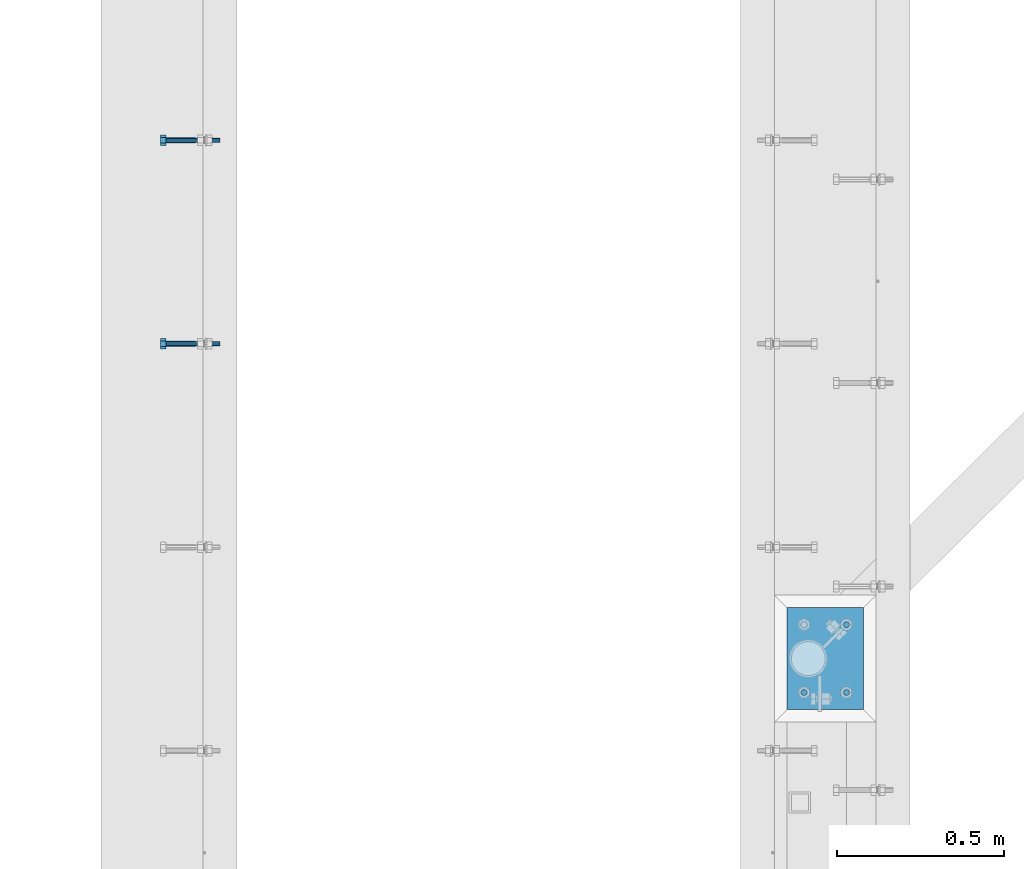
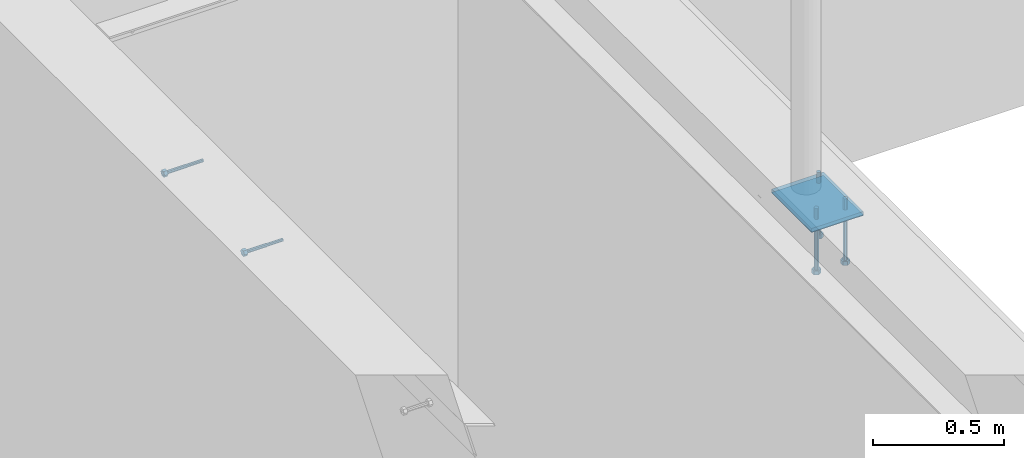
# One storey, part 419 of 975: 7 beams.
"""IFC2X3 building model written with IfcOpenShell, lengths in millimetres."""

from ifc_helpers import new_model, si_unit, frame, origin_with_axes, place, context, subcontext, project, spatial, faceted_brep, material, type_object, element, save


model = new_model("IFC2X3")

# Units and contexts
model_context = context("Model", 3, precision=1e-05, world=origin_with_axes())
body_context = subcontext(model_context, "Body", "Model", "MODEL_VIEW")
ifc_project = project(units=[si_unit("LENGTHUNIT", "METRE", prefix="MILLI"), si_unit("AREAUNIT", "SQUARE_METRE"), si_unit("VOLUMEUNIT", "CUBIC_METRE"), si_unit("MASSUNIT", "GRAM", prefix="KILO"), si_unit("TIMEUNIT", "SECOND"), si_unit("PLANEANGLEUNIT", "RADIAN"), si_unit("SOLIDANGLEUNIT", "STERADIAN"), si_unit("THERMODYNAMICTEMPERATUREUNIT", "DEGREE_CELSIUS"), si_unit("LUMINOUSINTENSITYUNIT", "LUMEN")], contexts=[model_context])

# Site, building, storey
site_placement = place(None, origin_with_axes())
site = spatial("IfcSite", under=ifc_project, at=site_placement, CompositionType="ELEMENT")
building_placement = place(site_placement, origin_with_axes())
building = spatial("IfcBuilding", under=site, at=building_placement, Name="Undefined", CompositionType="ELEMENT")
storey_placement = place(building_placement, origin_with_axes())
storey = spatial("IfcBuildingStorey", under=building, at=storey_placement, Name="Undefined", CompositionType="ELEMENT", Elevation=0.0)

# Beams
ifc_material_1 = material(Name="STEEL/F1554-36")
beam_type_1 = type_object("IfcBeamType", PredefinedType="NOTDEFINED")
beam_1_placement = place(storey_placement, frame((282.574953372507, 16951.3248045215, 3835.4), z_axis=(0.0, 0.0, -1.0), x_axis=(-0.999999999999998, 6.90000001668524e-08, 0.0)))
element("IfcBeam", 1, at=beam_1_placement, inside=storey, type_object=beam_type_1, material=ifc_material_1, Name="HEADED_ANCHOR_BOLT", context=body_context, shape_type="Brep", body=[
    faceted_brep([(88.9000000184824, 7.94000001861696, -13.7499999799138), (88.8999999527368, 15.8800000758411, 2.00943759409711e-08), (104.774999952569, 15.8800001213949, 6.97191353538074e-08), (104.775000018315, 7.94000006417082, -13.7499999302891), (88.900000064019, -7.94000009583215, -13.7499999799147), (104.775000063852, -7.9400000502792, -13.74999993029), (88.9000000438027, -15.880000153059, 2.00925569515675e-08), (104.775000043643, -15.8800001075042, 6.9716406869702e-08), (88.8999999780608, -7.94000009583488, 13.7500000200998), (104.774999977893, -7.94000005028101, 13.7500000697237), (88.8999999325279, 7.94000001861514, 13.7500000201007), (104.774999932361, 7.940000064169, 13.7500000697246), (88.9000000119959, 3.78780480527439, -7.86545778426807), (88.8999999957159, 6.82538844544797, -5.4430656647246), (88.8999999799416, 8.51112018845743, -1.94260763148395), (88.8999999677944, 8.51112018845652, 1.94260767167179), (88.8999999616899, 6.82538844544615, 5.44306570491244), (88.8999999628249, 3.78780480527257, 7.86545782445592), (88.8999999709849, -3.86089595849626e-08, 8.72999956233434), (88.8999999845473, -3.7878048824914, 7.8654578244541), (88.9000000008309, -6.82538852266407, 5.44306570491153), (88.9000000166052, -8.51112026567444, 1.94260767166998), (88.9000000287488, -8.51112026567353, -1.94260763148577), (88.9000000348606, -6.82538852266407, -5.44306566472642), (88.9000000337182, -3.78780488248958, -7.86545778426898), (88.9000000255583, -3.86080500902608e-08, -8.72999952214832), (104.775000025395, 6.94581103743985e-09, -8.72999947252447), (104.775000011829, 3.78780485082825, -7.86545773464422), (104.774999995549, 6.82538849100092, -5.44306561510075), (104.774999979774, 8.51112023401038, -1.9426075818601), (104.774999967627, 8.51112023401038, 1.94260772129564), (104.774999961523, 6.82538849100092, 5.44306575453629), (104.774999962658, 3.78780485082643, 7.86545787407977), (104.774999970818, 6.94399204803631e-09, 8.7299996119591), (104.77499998438, -3.78780483693754, 7.86545787407886), (104.775000000664, -6.82538847711112, 5.44306575453538), (104.775000016438, -8.51112022012057, 1.94260772129473), (104.775000028581, -8.51112022012057, -1.94260758186101), (104.775000034693, -6.82538847711021, -5.44306561510166), (104.775000033551, -3.78780483693663, -7.86545773464422), (-2.99107341561466e-07, -5.61266007567065, 5.61266007566792), (-4.22995071858168e-07, -7.93750000000728, 0.0), (104.774999998088, -7.93749999999, -4.45652403868735e-11), (104.774999998088, -5.61266007565791, 5.61266007562426), (-1.09139364212751e-11, 1.81898940354586e-12, 7.9375), (104.774999998095, 1.18234311230481e-11, 7.93749999995816), (2.99089151667431e-07, 5.61266007567428, 5.61266007566792), (104.774999998102, 5.61266007568065, 5.61266007562517), (4.22980519942939e-07, 7.93750000001091, 0.0), (104.77499999811, 7.93750000001364, -4.36557456851006e-11), (2.99089151667431e-07, 5.61266007567428, -5.61266007566792), (104.774999998102, 5.61266007568156, -5.61266007571339), (-1.09139364212751e-11, 1.81898940354586e-12, -7.9375), (104.774999998099, 1.2732925824821e-11, -7.93750000004547), (-73.0249999592124, 5.05157065939329, -5.0515715445581), (-73.0249999269472, -1.85405951924622e-07, -7.14400069976364), (-73.0249999328516, -5.0515710302052, -5.05157154455992), (-73.0249999734697, -7.14400018541073, -6.9975976657588e-07), (-73.0250000250016, -5.05157103020611, 5.05157014504039), (-73.0250000572705, -1.85406861419324e-07, 7.1439993002441), (-73.0250000513661, 5.05157065939238, 5.05157014503948), (-73.025000010748, 7.14399981459792, -6.99758857081179e-07), (0.00625003290042514, 5.05157085007795, -5.05157087849238), (0.00625006516929716, 5.27870724909008e-09, -7.1440000336961), (0.00625005926485755, -5.05157083952145, -5.05157087849329), (0.00625001864682417, -7.14399999472516, -3.36940502165817e-08), (0.00624996711121639, -5.05157083952145, 5.05157081110519), (0.00624993484598235, 5.2777977543883e-09, 7.14399996631164), (0.00624994074678398, 5.05157085007704, 5.05157081110701), (0.00624998136845534, 7.14400000528167, -3.36922312271781e-08), (-2.99107341561466e-07, -5.61266007567065, -5.61266007566792), (104.774999998092, -5.612660075657, -5.6126600757143)], [[[0, 1, 2, 3]], [[4, 0, 3, 5]], [[6, 4, 5, 7]], [[8, 6, 7, 9]], [[10, 8, 9, 11]], [[0, 4, 6, 8, 10, 1], [12, 13, 14, 15, 16, 17, 18, 19, 20, 21, 22, 23, 24, 25]], [[12, 25, 26, 27]], [[13, 12, 27, 28]], [[14, 13, 28, 29]], [[15, 14, 29, 30]], [[16, 15, 30, 31]], [[17, 16, 31, 32]], [[18, 17, 32, 33]], [[19, 18, 33, 34]], [[20, 19, 34, 35]], [[21, 20, 35, 36]], [[22, 21, 36, 37]], [[23, 22, 37, 38]], [[24, 23, 38, 39]], [[25, 24, 39, 26]], [[9, 7, 5, 3, 2, 11], [38, 37, 36, 35, 34, 33, 32, 31, 30, 29, 28, 27, 26, 39]], [[1, 10, 11, 2]], [[40, 41, 42, 43]], [[44, 40, 43, 45]], [[46, 44, 45, 47]], [[48, 46, 47, 49]], [[50, 48, 49, 51]], [[52, 50, 51, 53]], [[54, 55, 56, 57, 58, 59, 60, 61]], [[55, 54, 62, 63]], [[56, 55, 63, 64]], [[57, 56, 64, 65]], [[58, 57, 65, 66]], [[59, 58, 66, 67]], [[60, 59, 67, 68]], [[61, 60, 68, 69]], [[54, 61, 69, 62]], [[40, 44, 46, 48, 50, 52, 70, 41], [68, 67, 66, 65, 64, 63, 62, 69]], [[41, 70, 71, 42]], [[53, 51, 49, 47, 45, 43, 42, 71]], [[70, 52, 53, 71]]]),
])
beam_2_placement = place(storey_placement, frame((282.574957639707, 16341.7251951465, 3835.4), z_axis=(0.0, 0.0, -1.0), x_axis=(-0.999999999999998, 6.90000001668524e-08, 0.0)))
element("IfcBeam", 2, at=beam_2_placement, inside=storey, type_object=beam_type_1, material=ifc_material_1, Name="HEADED_ANCHOR_BOLT", context=body_context, shape_type="Brep", body=[
    faceted_brep([(88.9000000184824, 7.94000001861696, -13.7499999799138), (88.8999999527368, 15.8800000758411, 2.00943759409711e-08), (104.774999952569, 15.8800001213949, 6.97191353538074e-08), (104.775000018315, 7.94000006417082, -13.7499999302891), (88.900000064019, -7.94000009583215, -13.7499999799147), (104.775000063852, -7.9400000502792, -13.74999993029), (88.9000000438027, -15.880000153059, 2.00925569515675e-08), (104.775000043643, -15.8800001075042, 6.9716406869702e-08), (88.8999999780608, -7.94000009583488, 13.7500000200998), (104.774999977893, -7.94000005028101, 13.7500000697237), (88.8999999325279, 7.94000001861514, 13.7500000201007), (104.774999932361, 7.940000064169, 13.7500000697246), (88.9000000119959, 3.78780480527439, -7.86545778426807), (88.8999999957159, 6.82538844544797, -5.4430656647246), (88.8999999799416, 8.51112018845743, -1.94260763148395), (88.8999999677944, 8.51112018845652, 1.94260767167179), (88.8999999616899, 6.82538844544615, 5.44306570491244), (88.8999999628249, 3.78780480527257, 7.86545782445592), (88.8999999709849, -3.86089595849626e-08, 8.72999956233434), (88.8999999845473, -3.7878048824914, 7.8654578244541), (88.9000000008309, -6.82538852266407, 5.44306570491153), (88.9000000166052, -8.51112026567444, 1.94260767166998), (88.9000000287488, -8.51112026567353, -1.94260763148577), (88.9000000348606, -6.82538852266407, -5.44306566472642), (88.9000000337182, -3.78780488248958, -7.86545778426898), (88.9000000255583, -3.86080500902608e-08, -8.72999952214832), (104.775000025395, 6.94581103743985e-09, -8.72999947252447), (104.775000011829, 3.78780485082825, -7.86545773464422), (104.774999995549, 6.82538849100092, -5.44306561510075), (104.774999979774, 8.51112023401038, -1.9426075818601), (104.774999967627, 8.51112023401038, 1.94260772129564), (104.774999961523, 6.82538849100092, 5.44306575453629), (104.774999962658, 3.78780485082643, 7.86545787407977), (104.774999970818, 6.94399204803631e-09, 8.7299996119591), (104.77499998438, -3.78780483693754, 7.86545787407886), (104.775000000664, -6.82538847711112, 5.44306575453538), (104.775000016438, -8.51112022012057, 1.94260772129473), (104.775000028581, -8.51112022012057, -1.94260758186101), (104.775000034693, -6.82538847711021, -5.44306561510166), (104.775000033551, -3.78780483693663, -7.86545773464422), (-2.99107341561466e-07, -5.61266007567065, 5.61266007566792), (-4.22995071858168e-07, -7.93750000000728, 0.0), (104.774999998088, -7.93749999999, -4.45652403868735e-11), (104.774999998088, -5.61266007565791, 5.61266007562426), (-1.09139364212751e-11, 1.81898940354586e-12, 7.9375), (104.774999998095, 1.18234311230481e-11, 7.93749999995816), (2.99089151667431e-07, 5.61266007567428, 5.61266007566792), (104.774999998102, 5.61266007568065, 5.61266007562517), (4.22980519942939e-07, 7.93750000001091, 0.0), (104.77499999811, 7.93750000001364, -4.36557456851006e-11), (2.99089151667431e-07, 5.61266007567428, -5.61266007566792), (104.774999998102, 5.61266007568156, -5.61266007571339), (-1.09139364212751e-11, 1.81898940354586e-12, -7.9375), (104.774999998099, 1.2732925824821e-11, -7.93750000004547), (-73.0249999592124, 5.05157065939329, -5.0515715445581), (-73.0249999269472, -1.85405951924622e-07, -7.14400069976364), (-73.0249999328516, -5.0515710302052, -5.05157154455992), (-73.0249999734697, -7.14400018541073, -6.9975976657588e-07), (-73.0250000250016, -5.05157103020611, 5.05157014504039), (-73.0250000572705, -1.85406861419324e-07, 7.1439993002441), (-73.0250000513661, 5.05157065939238, 5.05157014503948), (-73.025000010748, 7.14399981459792, -6.99758857081179e-07), (0.00625003290042514, 5.05157085007795, -5.05157087849238), (0.00625006516929716, 5.27870724909008e-09, -7.1440000336961), (0.00625005926485755, -5.05157083952145, -5.05157087849329), (0.00625001864682417, -7.14399999472516, -3.36940502165817e-08), (0.00624996711121639, -5.05157083952145, 5.05157081110519), (0.00624993484598235, 5.2777977543883e-09, 7.14399996631164), (0.00624994074678398, 5.05157085007704, 5.05157081110701), (0.00624998136845534, 7.14400000528167, -3.36922312271781e-08), (-2.99107341561466e-07, -5.61266007567065, -5.61266007566792), (104.774999998092, -5.612660075657, -5.6126600757143)], [[[0, 1, 2, 3]], [[4, 0, 3, 5]], [[6, 4, 5, 7]], [[8, 6, 7, 9]], [[10, 8, 9, 11]], [[0, 4, 6, 8, 10, 1], [12, 13, 14, 15, 16, 17, 18, 19, 20, 21, 22, 23, 24, 25]], [[12, 25, 26, 27]], [[13, 12, 27, 28]], [[14, 13, 28, 29]], [[15, 14, 29, 30]], [[16, 15, 30, 31]], [[17, 16, 31, 32]], [[18, 17, 32, 33]], [[19, 18, 33, 34]], [[20, 19, 34, 35]], [[21, 20, 35, 36]], [[22, 21, 36, 37]], [[23, 22, 37, 38]], [[24, 23, 38, 39]], [[25, 24, 39, 26]], [[9, 7, 5, 3, 2, 11], [38, 37, 36, 35, 34, 33, 32, 31, 30, 29, 28, 27, 26, 39]], [[1, 10, 11, 2]], [[40, 41, 42, 43]], [[44, 40, 43, 45]], [[46, 44, 45, 47]], [[48, 46, 47, 49]], [[50, 48, 49, 51]], [[52, 50, 51, 53]], [[54, 55, 56, 57, 58, 59, 60, 61]], [[55, 54, 62, 63]], [[56, 55, 63, 64]], [[57, 56, 64, 65]], [[58, 57, 65, 66]], [[59, 58, 66, 67]], [[60, 59, 67, 68]], [[61, 60, 68, 69]], [[54, 61, 69, 62]], [[40, 44, 46, 48, 50, 52, 70, 41], [68, 67, 66, 65, 64, 63, 62, 69]], [[41, 70, 71, 42]], [[53, 51, 49, 47, 45, 43, 42, 71]], [[70, 52, 53, 71]]]),
])
beam_type_2 = type_object("IfcBeamType", PredefinedType="NOTDEFINED")
beam_3_placement = place(storey_placement, frame((2232.02500137409, 15500.3500011752, 3917.95), z_axis=(1.0, 0.0, 0.0), x_axis=(0.0, 0.0, -1.0)))
element("IfcBeam", 3, at=beam_3_placement, inside=storey, type_object=beam_type_2, material=ifc_material_1, Name="HEADED_BOLT", context=body_context, shape_type="Brep", body=[
    faceted_brep([(196.84375, -9.12999965559902, 15.8099993757314), (196.84375, -18.2599997700399, -1.0438852768857e-06), (215.893749999999, -18.2599997700399, -1.0438852768857e-06), (215.893749999999, -9.12999965559902, 15.8099993757314), (196.84375, 9.13000057328281, 15.8099993757314), (215.893749999999, 9.13000057328281, 15.8099993757314), (196.84375, 18.2600006877237, -1.0438852768857e-06), (215.893749999999, 18.2600006877237, -1.0438852768857e-06), (196.84375, 9.13000057328281, -15.810001463502), (215.893749999999, 9.13000057328281, -15.810001463502), (196.84375, -9.12999965559902, -15.810001463502), (215.893749999999, -9.12999965559902, -15.810001463502), (196.84375, -4.47767959644079, 9.2979973979138), (196.84375, -8.06850020163256, 6.43441352102286), (196.84375, -10.0612552973498, 2.29641492663589), (196.84375, -10.0612552973498, -2.29641701440644), (196.84375, -8.06850020163256, -6.43441560879344), (196.84375, -4.47767959644079, -9.29799948568439), (196.84375, 4.58841896033846e-07, -10.3200007387095), (196.84375, 4.47768051412459, -9.29799948568436), (196.84375, 8.06850111931635, -6.43441560879342), (196.84375, 10.0612562150336, -2.29641701440644), (196.84375, 10.0612562150336, 2.29641492663589), (196.84375, 8.06850111931635, 6.43441352102289), (196.84375, 4.47768051412459, 9.29799739791383), (196.84375, 4.58841896033846e-07, 10.3199986509389), (215.893749999999, 4.58841896033846e-07, 10.3199986509389), (215.893749999999, -4.47767959644079, 9.2979973979138), (215.893749999999, -8.06850020163256, 6.43441352102286), (215.893749999999, -10.0612552973498, 2.29641492663589), (215.893749999999, -10.0612552973498, -2.29641701440644), (215.893749999999, -8.06850020163256, -6.43441560879344), (215.893749999999, -4.47767959644079, -9.29799948568439), (215.893749999999, 4.58841896033846e-07, -10.3200007387095), (215.893749999999, 4.47768051412459, -9.29799948568436), (215.893749999999, 8.06850111931635, -6.43441560879342), (215.893749999999, 10.0612562150336, -2.29641701440644), (215.893749999999, 10.0612562150336, 2.29641492663589), (215.893749999999, 8.06850111931635, 6.43441352102289), (215.893749999999, 4.47768051412459, 9.29799739791383), (0.0, -6.73519209080223, 6.73519209080186), (0.0, -9.52499999999964, 0.0), (215.900000000001, -9.52499999999964, 0.0), (215.900000000001, -6.73519209080223, 6.73519209080186), (-9.87109982941227e-13, -1.20792265079217e-13, 9.52499961853027), (215.900000000001, 0.0, 9.52500000000001), (0.0, 6.73519209080223, 6.73519209080186), (215.900000000001, 6.73519209080223, 6.73519209080186), (0.0, 9.52499999999964, 0.0), (215.900000000001, 9.52499999999964, 0.0), (0.0, 6.73519209080223, -6.73519209080186), (215.900000000001, 6.73519209080223, -6.73519209080186), (2.95075507493764e-12, -1.20792265079217e-13, -9.52499961853027), (215.900000000001, 0.0, -9.52500000000001), (-88.9444446471748, -6.3639605718372, 6.39952908988423), (-88.9433906823501, 4.58841896033846e-07, 9.03556784850662), (-88.9444446471748, 6.36396148952099, 6.39952908988423), (-88.9469891433491, 9.0000004588419, 0.0355685678769078), (-88.9495336395235, 6.36396148952099, -6.32839195413041), (-88.9505876043481, 4.58841896033846e-07, -8.9644307127528), (-88.9495336395235, -6.3639605718372, -6.32839195413041), (-88.9469891433491, -8.9999995411581, 0.0355685678769078), (0.0124298302243915, 6.36396148952099, -6.36396152997716), (0.0113758653997138, 4.58841896033846e-07, -9.00000028859955), (0.0124298302243915, -6.3639605718372, -6.36396152997716), (0.0149743263987148, -8.9999995411581, -1.00796984270346e-06), (0.0175188225730381, -6.3639605718372, 6.36395951403748), (0.0185727873977157, 4.58841896033846e-07, 8.99999827265987), (0.0175188225730381, 6.36396148952099, 6.36395951403748), (0.0149743263987148, 9.0000004588419, -1.00796984270346e-06), (0.0, -6.73519209080223, -6.73519209080186), (215.900000000001, -6.73519209080223, -6.73519209080186)], [[[0, 1, 2, 3]], [[4, 0, 3, 5]], [[6, 4, 5, 7]], [[8, 6, 7, 9]], [[10, 8, 9, 11]], [[0, 4, 6, 8, 10, 1], [12, 13, 14, 15, 16, 17, 18, 19, 20, 21, 22, 23, 24, 25]], [[12, 25, 26, 27]], [[13, 12, 27, 28]], [[14, 13, 28, 29]], [[15, 14, 29, 30]], [[16, 15, 30, 31]], [[17, 16, 31, 32]], [[18, 17, 32, 33]], [[19, 18, 33, 34]], [[20, 19, 34, 35]], [[21, 20, 35, 36]], [[22, 21, 36, 37]], [[23, 22, 37, 38]], [[24, 23, 38, 39]], [[25, 24, 39, 26]], [[9, 7, 5, 3, 2, 11], [38, 37, 36, 35, 34, 33, 32, 31, 30, 29, 28, 27, 26, 39]], [[1, 10, 11, 2]], [[40, 41, 42, 43]], [[44, 40, 43, 45]], [[46, 44, 45, 47]], [[48, 46, 47, 49]], [[50, 48, 49, 51]], [[52, 50, 51, 53]], [[54, 55, 56, 57, 58, 59, 60, 61]], [[59, 58, 62, 63]], [[60, 59, 63, 64]], [[61, 60, 64, 65]], [[54, 61, 65, 66]], [[55, 54, 66, 67]], [[56, 55, 67, 68]], [[57, 56, 68, 69]], [[58, 57, 69, 62]], [[40, 44, 46, 48, 50, 52, 70, 41], [68, 67, 66, 65, 64, 63, 62, 69]], [[41, 70, 71, 42]], [[53, 51, 49, 47, 45, 43, 42, 71]], [[70, 52, 53, 71]]]),
])
beam_4_placement = place(storey_placement, frame((2232.02500137409, 15297.1500011752, 3917.95), z_axis=(1.0, 0.0, 0.0), x_axis=(0.0, 0.0, -1.0)))
element("IfcBeam", 4, at=beam_4_placement, inside=storey, type_object=beam_type_2, material=ifc_material_1, Name="HEADED_BOLT", context=body_context, shape_type="Brep", body=[
    faceted_brep([(196.84375, -9.12999965559902, 15.8099993757314), (196.84375, -18.2599997700399, -1.0438852768857e-06), (215.893749999999, -18.2599997700399, -1.0438852768857e-06), (215.893749999999, -9.12999965559902, 15.8099993757314), (196.84375, 9.13000057328281, 15.8099993757314), (215.893749999999, 9.13000057328281, 15.8099993757314), (196.84375, 18.2600006877237, -1.0438852768857e-06), (215.893749999999, 18.2600006877237, -1.0438852768857e-06), (196.84375, 9.13000057328281, -15.810001463502), (215.893749999999, 9.13000057328281, -15.810001463502), (196.84375, -9.12999965559902, -15.810001463502), (215.893749999999, -9.12999965559902, -15.810001463502), (196.84375, -4.47767959644079, 9.2979973979138), (196.84375, -8.06850020163256, 6.43441352102286), (196.84375, -10.0612552973498, 2.29641492663589), (196.84375, -10.0612552973498, -2.29641701440644), (196.84375, -8.06850020163256, -6.43441560879344), (196.84375, -4.47767959644079, -9.29799948568439), (196.84375, 4.58841896033846e-07, -10.3200007387095), (196.84375, 4.47768051412459, -9.29799948568436), (196.84375, 8.06850111931635, -6.43441560879342), (196.84375, 10.0612562150336, -2.29641701440644), (196.84375, 10.0612562150336, 2.29641492663589), (196.84375, 8.06850111931635, 6.43441352102289), (196.84375, 4.47768051412459, 9.29799739791383), (196.84375, 4.58841896033846e-07, 10.3199986509389), (215.893749999999, 4.58841896033846e-07, 10.3199986509389), (215.893749999999, -4.47767959644079, 9.2979973979138), (215.893749999999, -8.06850020163256, 6.43441352102286), (215.893749999999, -10.0612552973498, 2.29641492663589), (215.893749999999, -10.0612552973498, -2.29641701440644), (215.893749999999, -8.06850020163256, -6.43441560879344), (215.893749999999, -4.47767959644079, -9.29799948568439), (215.893749999999, 4.58841896033846e-07, -10.3200007387095), (215.893749999999, 4.47768051412459, -9.29799948568436), (215.893749999999, 8.06850111931635, -6.43441560879342), (215.893749999999, 10.0612562150336, -2.29641701440644), (215.893749999999, 10.0612562150336, 2.29641492663589), (215.893749999999, 8.06850111931635, 6.43441352102289), (215.893749999999, 4.47768051412459, 9.29799739791383), (0.0, -6.73519209080223, 6.73519209080186), (0.0, -9.52499999999964, 0.0), (215.900000000001, -9.52499999999964, 0.0), (215.900000000001, -6.73519209080223, 6.73519209080186), (-9.87109982941227e-13, -1.20792265079217e-13, 9.52499961853027), (215.900000000001, 0.0, 9.52500000000001), (0.0, 6.73519209080223, 6.73519209080186), (215.900000000001, 6.73519209080223, 6.73519209080186), (0.0, 9.52499999999964, 0.0), (215.900000000001, 9.52499999999964, 0.0), (0.0, 6.73519209080223, -6.73519209080186), (215.900000000001, 6.73519209080223, -6.73519209080186), (2.95075507493764e-12, -1.20792265079217e-13, -9.52499961853027), (215.900000000001, 0.0, -9.52500000000001), (-88.9444446471748, -6.3639605718372, 6.39952908988423), (-88.9433906823501, 4.58841896033846e-07, 9.03556784850662), (-88.9444446471748, 6.36396148952099, 6.39952908988423), (-88.9469891433491, 9.0000004588419, 0.0355685678769078), (-88.9495336395235, 6.36396148952099, -6.32839195413041), (-88.9505876043481, 4.58841896033846e-07, -8.9644307127528), (-88.9495336395235, -6.3639605718372, -6.32839195413041), (-88.9469891433491, -8.9999995411581, 0.0355685678769078), (0.0124298302243915, 6.36396148952099, -6.36396152997716), (0.0113758653997138, 4.58841896033846e-07, -9.00000028859955), (0.0124298302243915, -6.3639605718372, -6.36396152997716), (0.0149743263987148, -8.9999995411581, -1.00796984270346e-06), (0.0175188225730381, -6.3639605718372, 6.36395951403748), (0.0185727873977157, 4.58841896033846e-07, 8.99999827265987), (0.0175188225730381, 6.36396148952099, 6.36395951403748), (0.0149743263987148, 9.0000004588419, -1.00796984270346e-06), (0.0, -6.73519209080223, -6.73519209080186), (215.900000000001, -6.73519209080223, -6.73519209080186)], [[[0, 1, 2, 3]], [[4, 0, 3, 5]], [[6, 4, 5, 7]], [[8, 6, 7, 9]], [[10, 8, 9, 11]], [[0, 4, 6, 8, 10, 1], [12, 13, 14, 15, 16, 17, 18, 19, 20, 21, 22, 23, 24, 25]], [[12, 25, 26, 27]], [[13, 12, 27, 28]], [[14, 13, 28, 29]], [[15, 14, 29, 30]], [[16, 15, 30, 31]], [[17, 16, 31, 32]], [[18, 17, 32, 33]], [[19, 18, 33, 34]], [[20, 19, 34, 35]], [[21, 20, 35, 36]], [[22, 21, 36, 37]], [[23, 22, 37, 38]], [[24, 23, 38, 39]], [[25, 24, 39, 26]], [[9, 7, 5, 3, 2, 11], [38, 37, 36, 35, 34, 33, 32, 31, 30, 29, 28, 27, 26, 39]], [[1, 10, 11, 2]], [[40, 41, 42, 43]], [[44, 40, 43, 45]], [[46, 44, 45, 47]], [[48, 46, 47, 49]], [[50, 48, 49, 51]], [[52, 50, 51, 53]], [[54, 55, 56, 57, 58, 59, 60, 61]], [[59, 58, 62, 63]], [[60, 59, 63, 64]], [[61, 60, 64, 65]], [[54, 61, 65, 66]], [[55, 54, 66, 67]], [[56, 55, 67, 68]], [[57, 56, 68, 69]], [[58, 57, 69, 62]], [[40, 44, 46, 48, 50, 52, 70, 41], [68, 67, 66, 65, 64, 63, 62, 69]], [[41, 70, 71, 42]], [[53, 51, 49, 47, 45, 43, 42, 71]], [[70, 52, 53, 71]]]),
])
beam_5_placement = place(storey_placement, frame((2105.02500137408, 15297.1500011752, 3917.95), z_axis=(1.0, 0.0, 0.0), x_axis=(0.0, 0.0, -1.0)))
element("IfcBeam", 5, at=beam_5_placement, inside=storey, type_object=beam_type_2, material=ifc_material_1, Name="HEADED_BOLT", context=body_context, shape_type="Brep", body=[
    faceted_brep([(196.84375, -9.12999965559902, 15.8099993757314), (196.84375, -18.2599997700399, -1.0438852768857e-06), (215.893749999999, -18.2599997700399, -1.0438852768857e-06), (215.893749999999, -9.12999965559902, 15.8099993757314), (196.84375, 9.13000057328281, 15.8099993757314), (215.893749999999, 9.13000057328281, 15.8099993757314), (196.84375, 18.2600006877237, -1.0438852768857e-06), (215.893749999999, 18.2600006877237, -1.0438852768857e-06), (196.84375, 9.13000057328281, -15.810001463502), (215.893749999999, 9.13000057328281, -15.810001463502), (196.84375, -9.12999965559902, -15.810001463502), (215.893749999999, -9.12999965559902, -15.810001463502), (196.84375, -4.47767959644079, 9.2979973979138), (196.84375, -8.06850020163256, 6.43441352102286), (196.84375, -10.0612552973498, 2.29641492663589), (196.84375, -10.0612552973498, -2.29641701440644), (196.84375, -8.06850020163256, -6.43441560879344), (196.84375, -4.47767959644079, -9.29799948568439), (196.84375, 4.58841896033846e-07, -10.3200007387095), (196.84375, 4.47768051412459, -9.29799948568436), (196.84375, 8.06850111931635, -6.43441560879342), (196.84375, 10.0612562150336, -2.29641701440644), (196.84375, 10.0612562150336, 2.29641492663589), (196.84375, 8.06850111931635, 6.43441352102289), (196.84375, 4.47768051412459, 9.29799739791383), (196.84375, 4.58841896033846e-07, 10.3199986509389), (215.893749999999, 4.58841896033846e-07, 10.3199986509389), (215.893749999999, -4.47767959644079, 9.2979973979138), (215.893749999999, -8.06850020163256, 6.43441352102286), (215.893749999999, -10.0612552973498, 2.29641492663589), (215.893749999999, -10.0612552973498, -2.29641701440644), (215.893749999999, -8.06850020163256, -6.43441560879344), (215.893749999999, -4.47767959644079, -9.29799948568439), (215.893749999999, 4.58841896033846e-07, -10.3200007387095), (215.893749999999, 4.47768051412459, -9.29799948568436), (215.893749999999, 8.06850111931635, -6.43441560879342), (215.893749999999, 10.0612562150336, -2.29641701440644), (215.893749999999, 10.0612562150336, 2.29641492663589), (215.893749999999, 8.06850111931635, 6.43441352102289), (215.893749999999, 4.47768051412459, 9.29799739791383), (0.0, -6.73519209080223, 6.73519209080186), (0.0, -9.52499999999964, 0.0), (215.900000000001, -9.52499999999964, 0.0), (215.900000000001, -6.73519209080223, 6.73519209080186), (-9.87109982941227e-13, -1.20792265079217e-13, 9.52499961853027), (215.900000000001, 0.0, 9.52500000000001), (0.0, 6.73519209080223, 6.73519209080186), (215.900000000001, 6.73519209080223, 6.73519209080186), (0.0, 9.52499999999964, 0.0), (215.900000000001, 9.52499999999964, 0.0), (0.0, 6.73519209080223, -6.73519209080186), (215.900000000001, 6.73519209080223, -6.73519209080186), (2.95075507493764e-12, -1.20792265079217e-13, -9.52499961853027), (215.900000000001, 0.0, -9.52500000000001), (-88.9444446471748, -6.3639605718372, 6.39952908988423), (-88.9433906823501, 4.58841896033846e-07, 9.03556784850662), (-88.9444446471748, 6.36396148952099, 6.39952908988423), (-88.9469891433491, 9.0000004588419, 0.0355685678769078), (-88.9495336395235, 6.36396148952099, -6.32839195413041), (-88.9505876043481, 4.58841896033846e-07, -8.9644307127528), (-88.9495336395235, -6.3639605718372, -6.32839195413041), (-88.9469891433491, -8.9999995411581, 0.0355685678769078), (0.0124298302243915, 6.36396148952099, -6.36396152997716), (0.0113758653997138, 4.58841896033846e-07, -9.00000028859955), (0.0124298302243915, -6.3639605718372, -6.36396152997716), (0.0149743263987148, -8.9999995411581, -1.00796984270346e-06), (0.0175188225730381, -6.3639605718372, 6.36395951403748), (0.0185727873977157, 4.58841896033846e-07, 8.99999827265987), (0.0175188225730381, 6.36396148952099, 6.36395951403748), (0.0149743263987148, 9.0000004588419, -1.00796984270346e-06), (0.0, -6.73519209080223, -6.73519209080186), (215.900000000001, -6.73519209080223, -6.73519209080186)], [[[0, 1, 2, 3]], [[4, 0, 3, 5]], [[6, 4, 5, 7]], [[8, 6, 7, 9]], [[10, 8, 9, 11]], [[0, 4, 6, 8, 10, 1], [12, 13, 14, 15, 16, 17, 18, 19, 20, 21, 22, 23, 24, 25]], [[12, 25, 26, 27]], [[13, 12, 27, 28]], [[14, 13, 28, 29]], [[15, 14, 29, 30]], [[16, 15, 30, 31]], [[17, 16, 31, 32]], [[18, 17, 32, 33]], [[19, 18, 33, 34]], [[20, 19, 34, 35]], [[21, 20, 35, 36]], [[22, 21, 36, 37]], [[23, 22, 37, 38]], [[24, 23, 38, 39]], [[25, 24, 39, 26]], [[9, 7, 5, 3, 2, 11], [38, 37, 36, 35, 34, 33, 32, 31, 30, 29, 28, 27, 26, 39]], [[1, 10, 11, 2]], [[40, 41, 42, 43]], [[44, 40, 43, 45]], [[46, 44, 45, 47]], [[48, 46, 47, 49]], [[50, 48, 49, 51]], [[52, 50, 51, 53]], [[54, 55, 56, 57, 58, 59, 60, 61]], [[59, 58, 62, 63]], [[60, 59, 63, 64]], [[61, 60, 64, 65]], [[54, 61, 65, 66]], [[55, 54, 66, 67]], [[56, 55, 67, 68]], [[57, 56, 68, 69]], [[58, 57, 69, 62]], [[40, 44, 46, 48, 50, 52, 70, 41], [68, 67, 66, 65, 64, 63, 62, 69]], [[41, 70, 71, 42]], [[53, 51, 49, 47, 45, 43, 42, 71]], [[70, 52, 53, 71]]]),
])
ifc_material_2 = material(Name="STEEL/A36")
beam_type_3 = type_object("IfcBeamType", PredefinedType="NOTDEFINED")
beam_6_placement = place(storey_placement, frame((2054.2249998482, 15398.7500011752, 3946.525), z_axis=(0.0, 1.0, 0.0), x_axis=(1.0, 0.0, 0.0)))
element("IfcBeam", 6, at=beam_6_placement, inside=storey, type_object=beam_type_3, material=ifc_material_2, Name="PLATE", context=body_context, shape_type="Brep", body=[
    faceted_brep([(0.0, 9.52499999999964, -152.4), (0.0, 9.52499999999964, 152.4), (228.600003051761, 9.52500000000009, 152.4), (228.600003051761, 9.52500000000009, -152.4), (0.0, -9.52499999999964, 152.4), (228.600003051761, -9.52500000000009, 152.4), (0.0, -9.52499999999964, -152.4), (228.600003051761, -9.52500000000009, -152.4)], [[[0, 1, 2, 3]], [[1, 4, 5, 2]], [[4, 6, 7, 5]], [[6, 0, 3, 7]], [[5, 7, 3, 2]], [[6, 4, 1, 0]]]),
])
beam_type_4 = type_object("IfcBeamType", PredefinedType="NOTDEFINED")
beam_7_placement = place(storey_placement, frame((2054.2249998482, 15398.7500011752, 3938.5875), z_axis=(0.0, 1.0, 0.0), x_axis=(1.0, 0.0, 0.0)))
element("IfcBeam", 7, at=beam_7_placement, inside=storey, type_object=beam_type_4, material=ifc_material_2, Name="TEMPLATE", context=body_context, shape_type="Brep", body=[
    faceted_brep([(0.0, 1.58750000000009, -152.4), (0.0, 1.58750000000009, 152.4), (228.600003051761, 1.58750000000009, 152.4), (228.600003051761, 1.58750000000009, -152.4), (0.0, -1.58750000000009, 152.4), (228.600003051761, -1.58750000000009, 152.4), (0.0, -1.58750000000009, -152.4), (228.600003051761, -1.58750000000009, -152.4)], [[[0, 1, 2, 3]], [[1, 4, 5, 2]], [[4, 6, 7, 5]], [[6, 0, 3, 7]], [[5, 7, 3, 2]], [[6, 4, 1, 0]]]),
])

save(model, "model.ifc")
